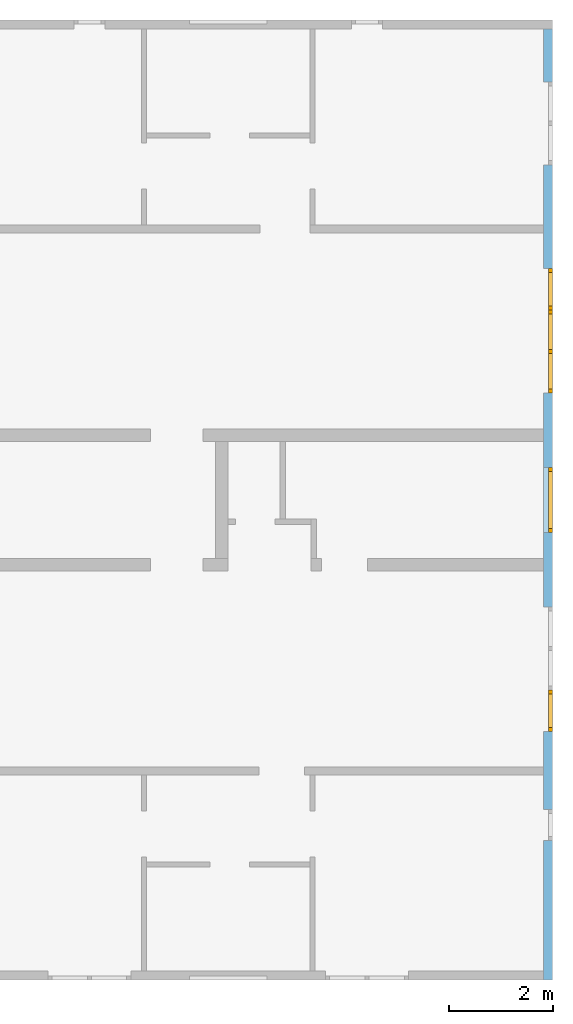
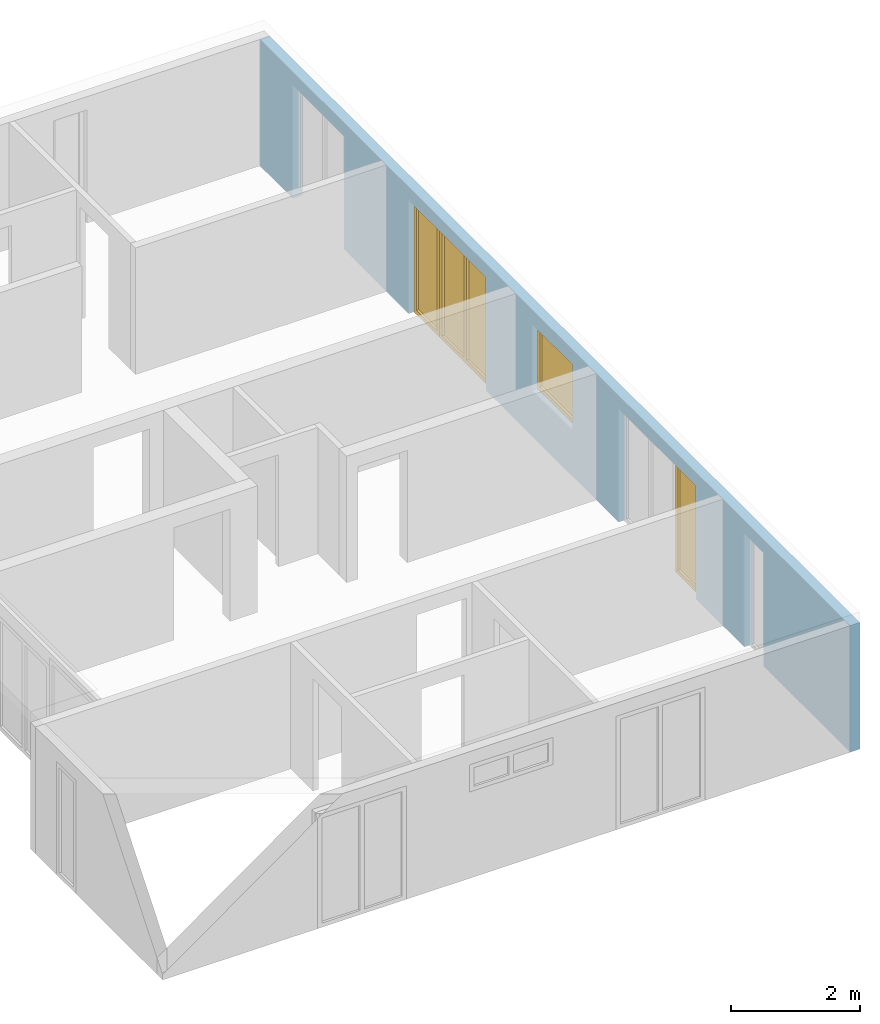
# One storey, part 7 of 8: 4 windows, 7 openings, plus 1 element that does not belong to this part.
"""IFC2X3 building model written with IfcOpenShell, lengths in millimetres."""

from ifc_helpers import new_model, entity, si_unit, converted_unit, frame, frame_2d, origin, origin_with_axes, place, context, project, spatial, rectangle, extrude, faceted_brep, material, layer, layer_set, layer_usage, element, fill, save


model = new_model("IFC2X3")

# Units and contexts
model_context = context("Model", 3, precision=1e-05, world=origin())
plan_context = context("Plan", 3, precision=1e-05, world=origin())
ifc_project = project(units=[si_unit("LENGTHUNIT", "METRE", prefix="MILLI"), converted_unit("PLANEANGLEUNIT", "DEGREE", entity("IfcPlaneAngleMeasure", 0.0174532925199433), si_unit("PLANEANGLEUNIT", "RADIAN"), dimensions=[0, 0, 0, 0, 0, 0, 0]), si_unit("AREAUNIT", "SQUARE_METRE"), si_unit("VOLUMEUNIT", "CUBIC_METRE")], contexts=[model_context, plan_context])

# Building, storey
building_placement = place(None, origin())
building = spatial("IfcBuilding", under=ifc_project, at=building_placement, CompositionType="ELEMENT")
storey_placement = place(building_placement, frame((0.0, 0.0, 2900.0), z_axis=(0.0, 0.0, 1.0), x_axis=(1.0, 0.0, 0.0)))
storey = spatial("IfcBuildingStorey", under=building, at=storey_placement, Name="OG", CompositionType="ELEMENT", Elevation=2900.0)

# Wall, openings, windows
ifc_material_1 = material(Name="B25")
ifc_layer = layer(ifc_material_1, 175.000000044703)
ifc_layer_set = layer_set([ifc_layer])
ifc_layer_usage = layer_usage(ifc_layer_set, "AXIS2", "POSITIVE", 0.0)
wall_placement = place(storey_placement, frame((33688.3517822139, -8691.5625, 0.0), z_axis=(0.0, 0.0, 1.0), x_axis=(0.0, 1.0, 0.0)))
wall = element("IfcWallStandardCase", 1, at=wall_placement, inside=storey, material=ifc_layer_usage, context=model_context, shape_type="SweptSolid", body=[
    extrude(rectangle(XDim=18325.0, YDim=175.000000044703, at=frame_2d((9162.5, 87.5000000223517), x_axis=(1.0, 0.0))), origin_with_axes(), (0.0, 0.0, 1.0), 2400.0),
])
opening_1_placement = place(wall_placement, frame((2690.0, 0.0, 0.0), z_axis=(0.0, 1.0, 0.0), x_axis=(0.0, 0.0, 1.0)))
element("IfcOpeningElement", 2, at=opening_1_placement, cuts=wall, ObjectType="Opening", context=model_context, shape_type="SweptSolid", body=[
    extrude(rectangle(XDim=2150.0, YDim=600.0, at=frame_2d((1075.0, 300.0), x_axis=(1.0, 0.0))), origin_with_axes(), (0.0, 0.0, 1.0), 175.000000044703),
])
opening_2_placement = place(wall_placement, frame((5590.0, 0.0, 0.0), z_axis=(0.0, 1.0, 0.0), x_axis=(0.0, 0.0, 1.0)))
element("IfcOpeningElement", 3, at=opening_2_placement, cuts=wall, ObjectType="Opening", context=model_context, shape_type="SweptSolid", body=[
    extrude(rectangle(XDim=2150.0, YDim=1600.0, at=frame_2d((1075.0, 800.0), x_axis=(1.0, 0.0))), origin_with_axes(), (0.0, 0.0, 1.0), 175.000000044703),
])
opening_3_placement = place(wall_placement, frame((15710.0, 0.0, 0.0), z_axis=(0.0, 1.0, 0.0), x_axis=(0.0, 0.0, 1.0)))
element("IfcOpeningElement", 4, at=opening_3_placement, cuts=wall, ObjectType="Opening", context=model_context, shape_type="SweptSolid", body=[
    extrude(rectangle(XDim=2150.0, YDim=1600.0, at=frame_2d((1075.0, 800.0), x_axis=(1.0, 0.0))), origin_with_axes(), (0.0, 0.0, 1.0), 175.000000044703),
])
opening_4_placement = place(wall_placement, frame((8625.0, 1.86264514923096e-09, 875.0), z_axis=(0.0, 1.0, 0.0), x_axis=(0.0, 0.0, 1.0)))
opening_4 = element("IfcOpeningElement", 5, at=opening_4_placement, cuts=wall, ObjectType="Opening", context=model_context, shape_type="SweptSolid", body=[
    extrude(rectangle(XDim=1250.0, YDim=1250.0, at=frame_2d((625.0, 625.0), x_axis=(1.0, 0.0))), origin_with_axes(), (0.0, 0.0, 1.0), 175.000000044703),
])
opening_5_placement = place(wall_placement, frame((4790.0, 0.0, 0.0), z_axis=(0.0, 1.0, 0.0), x_axis=(0.0, 0.0, 1.0)))
opening_5 = element("IfcOpeningElement", 6, at=opening_5_placement, cuts=wall, ObjectType="Opening", context=model_context, shape_type="SweptSolid", body=[
    extrude(rectangle(XDim=2150.0, YDim=800.0, at=frame_2d((1075.0, 400.0), x_axis=(1.0, 0.0))), origin_with_axes(), (0.0, 0.0, 1.0), 175.000000044703),
])
opening_6_placement = place(wall_placement, frame((12910.0, 0.0, 0.0), z_axis=(0.0, 1.0, 0.0), x_axis=(0.0, 0.0, 1.0)))
opening_6 = element("IfcOpeningElement", 7, at=opening_6_placement, cuts=wall, ObjectType="Opening", context=model_context, shape_type="SweptSolid", body=[
    extrude(rectangle(XDim=2150.0, YDim=800.0, at=frame_2d((1075.0, 400.0), x_axis=(1.0, 0.0))), origin_with_axes(), (0.0, 0.0, 1.0), 175.000000044703),
])
opening_7_placement = place(wall_placement, frame((11310.0, 0.0, 0.0), z_axis=(0.0, 1.0, 0.0), x_axis=(0.0, 0.0, 1.0)))
opening_7 = element("IfcOpeningElement", 8, at=opening_7_placement, cuts=wall, ObjectType="Opening", context=model_context, shape_type="SweptSolid", body=[
    extrude(rectangle(XDim=2150.0, YDim=1600.0, at=frame_2d((1075.0, 800.0), x_axis=(1.0, 0.0))), origin_with_axes(), (0.0, 0.0, 1.0), 175.000000044703),
])
ifc_material_2 = material()
window_1_placement = place(opening_4_placement, frame((0.0, 0.0, 0.0), z_axis=(1.0, 0.0, 0.0), x_axis=(0.0, 1.0, 0.0)))
window_1 = element("IfcWindow", 9, at=window_1_placement, inside=storey, material=ifc_material_2, Name="m", OverallHeight=1250.0, OverallWidth=1250.0, context=model_context, shape_type="Brep", body=[
    faceted_brep([(1170.0, -1.66655578226482e-12, 0.0), (1170.0, -1.66655578226482e-12, 1250.0), (1250.0, -1.68121072618987e-12, 1250.0), (1250.0, -1.68121072618987e-12, 0.0), (1250.0, 79.9999999999983, 0.0), (1250.0, 79.9999999999983, 1250.0), (1170.0, 79.9999999999983, 1250.0), (1170.0, 79.9999999999983, 0.0), (1250.0, -1.68121072618987e-12, 0.0), (1250.0, 79.9999999999983, 0.0), (1170.0, 79.9999999999983, 0.0), (1170.0, -1.66655578226482e-12, 0.0), (1250.0, -1.68121072618987e-12, 1250.0), (1250.0, 79.9999999999983, 1250.0), (1250.0, 79.9999999999983, 0.0), (1250.0, -1.68121072618987e-12, 0.0), (1170.0, -1.66655578226482e-12, 1250.0), (1170.0, 79.9999999999983, 1250.0), (1250.0, 79.9999999999983, 1250.0), (1250.0, -1.68121072618987e-12, 1250.0), (1170.0, -1.66655578226482e-12, 0.0), (1170.0, 79.9999999999983, 0.0), (1170.0, 79.9999999999983, 1250.0), (1170.0, -1.66655578226482e-12, 1250.0)], [[[0, 1, 2, 3]], [[4, 5, 6, 7]], [[8, 9, 10, 11]], [[12, 13, 14, 15]], [[16, 17, 18, 19]], [[20, 21, 22, 23]]], orient=[[False], [False], [False], [False], [False], [False]]),
    faceted_brep([(80.0, -1.46982426230124e-12, 1250.0), (80.0, -1.46982426230124e-12, 0.0), (-1.4321069287046e-14, -1.45516931837619e-12, 0.0), (-1.4321069287046e-14, -1.45516931837619e-12, 1250.0), (3.74206958822511e-16, 79.9999999999986, 1250.0), (3.74206958822511e-16, 79.9999999999986, 0.0), (80.0, 79.9999999999985, 0.0), (80.0, 79.9999999999985, 1250.0), (-1.4321069287046e-14, -1.45516931837619e-12, 1250.0), (3.74206958822511e-16, 79.9999999999986, 1250.0), (80.0, 79.9999999999985, 1250.0), (80.0, -1.46982426230124e-12, 1250.0), (-1.4321069287046e-14, -1.45516931837619e-12, 0.0), (3.74206958822511e-16, 79.9999999999986, 0.0), (3.74206958822511e-16, 79.9999999999986, 1250.0), (-1.4321069287046e-14, -1.45516931837619e-12, 1250.0), (80.0, -1.46982426230124e-12, 0.0), (80.0, 79.9999999999985, 0.0), (3.74206958822511e-16, 79.9999999999986, 0.0), (-1.4321069287046e-14, -1.45516931837619e-12, 0.0), (80.0, -1.46982426230124e-12, 1250.0), (80.0, 79.9999999999985, 1250.0), (80.0, 79.9999999999985, 0.0), (80.0, -1.46982426230124e-12, 0.0)], [[[0, 1, 2, 3]], [[4, 5, 6, 7]], [[8, 9, 10, 11]], [[12, 13, 14, 15]], [[16, 17, 18, 19]], [[20, 21, 22, 23]]], orient=[[False], [False], [False], [False], [False], [False]]),
    faceted_brep([(1170.0, -1.65589764122842e-12, 1170.0), (80.0, -1.45561340758604e-12, 1170.0), (80.0, -1.45561340758604e-12, 1250.0), (1170.0, -1.65589764122842e-12, 1250.0), (1170.0, 79.9999999999984, 1250.0), (80.0, 79.9999999999986, 1250.0), (80.0, 79.9999999999986, 1170.0), (1170.0, 79.9999999999984, 1170.0), (1170.0, -1.65589764122842e-12, 1250.0), (1170.0, 79.9999999999984, 1250.0), (1170.0, 79.9999999999984, 1170.0), (1170.0, -1.65589764122842e-12, 1170.0), (80.0, -1.45561340758604e-12, 1250.0), (80.0, 79.9999999999986, 1250.0), (1170.0, 79.9999999999984, 1250.0), (1170.0, -1.65589764122842e-12, 1250.0), (80.0, -1.45561340758604e-12, 1170.0), (80.0, 79.9999999999986, 1170.0), (80.0, 79.9999999999986, 1250.0), (80.0, -1.45561340758604e-12, 1250.0), (1170.0, -1.65589764122842e-12, 1170.0), (1170.0, 79.9999999999984, 1170.0), (80.0, 79.9999999999986, 1170.0), (80.0, -1.45561340758604e-12, 1170.0)], [[[0, 1, 2, 3]], [[4, 5, 6, 7]], [[8, 9, 10, 11]], [[12, 13, 14, 15]], [[16, 17, 18, 19]], [[20, 21, 22, 23]]], orient=[[False], [False], [False], [False], [False], [False]]),
    faceted_brep([(80.0, -1.45561340758604e-12, 80.0), (1170.0, -1.65589764122842e-12, 80.0), (1170.0, -1.65589764122842e-12, 0.0), (80.0, -1.45561340758604e-12, 0.0), (80.0, 79.9999999999986, 0.0), (1170.0, 79.9999999999984, 0.0), (1170.0, 79.9999999999984, 80.0), (80.0, 79.9999999999986, 80.0), (80.0, -1.45561340758604e-12, 0.0), (80.0, 79.9999999999986, 0.0), (80.0, 79.9999999999986, 80.0), (80.0, -1.45561340758604e-12, 80.0), (1170.0, -1.65589764122842e-12, 0.0), (1170.0, 79.9999999999984, 0.0), (80.0, 79.9999999999986, 0.0), (80.0, -1.45561340758604e-12, 0.0), (1170.0, -1.65589764122842e-12, 80.0), (1170.0, 79.9999999999984, 80.0), (1170.0, 79.9999999999984, 0.0), (1170.0, -1.65589764122842e-12, 0.0), (80.0, -1.45561340758604e-12, 80.0), (80.0, 79.9999999999986, 80.0), (1170.0, 79.9999999999984, 80.0), (1170.0, -1.65589764122842e-12, 80.0)], [[[0, 1, 2, 3]], [[4, 5, 6, 7]], [[8, 9, 10, 11]], [[12, 13, 14, 15]], [[16, 17, 18, 19]], [[20, 21, 22, 23]]], orient=[[False], [False], [False], [False], [False], [False]]),
    faceted_brep([(1170.0, 39.9999999999983, 80.0), (80.0, 39.9999999999985, 80.0), (80.0, 39.9999999999985, 1170.0), (1170.0, 39.9999999999983, 1170.0), (1170.0, 40.9999999999983, 80.0), (1170.0, 40.9999999999983, 1170.0), (80.0, 40.9999999999985, 1170.0), (80.0, 40.9999999999985, 80.0), (1170.0, 39.9999999999983, 80.0), (1170.0, 40.9999999999983, 80.0), (80.0, 40.9999999999985, 80.0), (80.0, 39.9999999999985, 80.0), (80.0, 39.9999999999985, 80.0), (80.0, 40.9999999999985, 80.0), (80.0, 40.9999999999985, 1170.0), (80.0, 39.9999999999985, 1170.0), (80.0, 39.9999999999985, 1170.0), (80.0, 40.9999999999985, 1170.0), (1170.0, 40.9999999999983, 1170.0), (1170.0, 39.9999999999983, 1170.0), (1170.0, 39.9999999999983, 1170.0), (1170.0, 40.9999999999983, 1170.0), (1170.0, 40.9999999999983, 80.0), (1170.0, 39.9999999999983, 80.0)], [[[0, 1, 2, 3]], [[4, 5, 6, 7]], [[8, 9, 10, 11]], [[12, 13, 14, 15]], [[16, 17, 18, 19]], [[20, 21, 22, 23]]], orient=[[False], [False], [False], [False], [False], [False]]),
])
fill(opening_4, window_1)
ifc_material_3 = material()
window_2_placement = place(opening_5_placement, frame((0.0, 0.0, 0.0), z_axis=(1.0, 0.0, 0.0), x_axis=(0.0, 1.0, 0.0)))
window_2 = element("IfcWindow", 10, at=window_2_placement, inside=storey, material=ifc_material_3, Name="m", OverallHeight=2150.0, OverallWidth=800.0, context=model_context, shape_type="Brep", body=[
    faceted_brep([(80.0, 4.19088097558529e-11, 0.0), (0.0, 4.19235757220804e-11, 0.0), (0.0, 4.19235757220804e-11, 2150.0), (80.0, 4.19088097558529e-11, 2150.0), (0.0, 80.0000000000419, 0.0), (80.0, 80.0000000000419, 0.0), (80.0, 80.0000000000419, 2150.0), (0.0, 80.0000000000419, 2150.0), (0.0, 4.19235757220804e-11, 0.0), (80.0, 4.19088097558529e-11, 0.0), (80.0, 80.0000000000419, 0.0), (0.0, 80.0000000000419, 0.0), (0.0, 4.19235757220804e-11, 2150.0), (0.0, 4.19235757220804e-11, 0.0), (0.0, 80.0000000000419, 0.0), (0.0, 80.0000000000419, 2150.0), (80.0, 4.19088097558529e-11, 2150.0), (0.0, 4.19235757220804e-11, 2150.0), (0.0, 80.0000000000419, 2150.0), (80.0, 80.0000000000419, 2150.0), (80.0, 4.19088097558529e-11, 0.0), (80.0, 4.19088097558529e-11, 2150.0), (80.0, 80.0000000000419, 2150.0), (80.0, 80.0000000000419, 0.0)], [[[0, 1, 2, 3]], [[4, 5, 6, 7]], [[8, 9, 10, 11]], [[12, 13, 14, 15]], [[16, 17, 18, 19]], [[20, 21, 22, 23]]], orient=[[False], [False], [False], [False], [False], [False]]),
    faceted_brep([(720.0, 4.17628154281147e-11, 2150.0), (800.0, 4.17481604841896e-11, 2150.0), (800.0, 4.17481604841896e-11, 0.0), (720.0, 4.17628154281147e-11, 0.0), (800.0, 80.0000000000418, 2150.0), (720.0, 80.0000000000418, 2150.0), (720.0, 80.0000000000418, 0.0), (800.0, 80.0000000000418, 0.0), (800.0, 4.17481604841896e-11, 2150.0), (720.0, 4.17628154281147e-11, 2150.0), (720.0, 80.0000000000418, 2150.0), (800.0, 80.0000000000418, 2150.0), (800.0, 4.17481604841896e-11, 0.0), (800.0, 4.17481604841896e-11, 2150.0), (800.0, 80.0000000000418, 2150.0), (800.0, 80.0000000000418, 0.0), (720.0, 4.17628154281147e-11, 0.0), (800.0, 4.17481604841896e-11, 0.0), (800.0, 80.0000000000418, 0.0), (720.0, 80.0000000000418, 0.0), (720.0, 4.17628154281147e-11, 2150.0), (720.0, 4.17628154281147e-11, 0.0), (720.0, 80.0000000000418, 0.0), (720.0, 80.0000000000418, 2150.0)], [[[0, 1, 2, 3]], [[4, 5, 6, 7]], [[8, 9, 10, 11]], [[12, 13, 14, 15]], [[16, 17, 18, 19]], [[20, 21, 22, 23]]], orient=[[False], [False], [False], [False], [False], [False]]),
    faceted_brep([(720.0, 4.17486045733995e-11, 80.0), (720.0, 4.17486045733995e-11, 0.0), (80.0, 4.18661771917073e-11, 0.0), (80.0, 4.18661771917073e-11, 80.0), (720.0, 80.0000000000418, 0.0), (720.0, 80.0000000000418, 80.0), (80.0, 80.0000000000419, 80.0), (80.0, 80.0000000000419, 0.0), (720.0, 4.17486045733995e-11, 0.0), (720.0, 4.17486045733995e-11, 80.0), (720.0, 80.0000000000418, 80.0), (720.0, 80.0000000000418, 0.0), (80.0, 4.18661771917073e-11, 0.0), (720.0, 4.17486045733995e-11, 0.0), (720.0, 80.0000000000418, 0.0), (80.0, 80.0000000000419, 0.0), (80.0, 4.18661771917073e-11, 80.0), (80.0, 4.18661771917073e-11, 0.0), (80.0, 80.0000000000419, 0.0), (80.0, 80.0000000000419, 80.0), (720.0, 4.17486045733995e-11, 80.0), (80.0, 4.18661771917073e-11, 80.0), (80.0, 80.0000000000419, 80.0), (720.0, 80.0000000000418, 80.0)], [[[0, 1, 2, 3]], [[4, 5, 6, 7]], [[8, 9, 10, 11]], [[12, 13, 14, 15]], [[16, 17, 18, 19]], [[20, 21, 22, 23]]], orient=[[False], [False], [False], [False], [False], [False]]),
    faceted_brep([(80.0, 4.18661771917073e-11, 2070.0), (80.0, 4.18661771917073e-11, 2150.0), (720.0, 4.17486045733995e-11, 2150.0), (720.0, 4.17486045733995e-11, 2070.0), (80.0, 80.0000000000419, 2150.0), (80.0, 80.0000000000419, 2070.0), (720.0, 80.0000000000418, 2070.0), (720.0, 80.0000000000418, 2150.0), (80.0, 4.18661771917073e-11, 2150.0), (80.0, 4.18661771917073e-11, 2070.0), (80.0, 80.0000000000419, 2070.0), (80.0, 80.0000000000419, 2150.0), (720.0, 4.17486045733995e-11, 2150.0), (80.0, 4.18661771917073e-11, 2150.0), (80.0, 80.0000000000419, 2150.0), (720.0, 80.0000000000418, 2150.0), (720.0, 4.17486045733995e-11, 2070.0), (720.0, 4.17486045733995e-11, 2150.0), (720.0, 80.0000000000418, 2150.0), (720.0, 80.0000000000418, 2070.0), (80.0, 4.18661771917073e-11, 2070.0), (720.0, 4.17486045733995e-11, 2070.0), (720.0, 80.0000000000418, 2070.0), (80.0, 80.0000000000419, 2070.0)], [[[0, 1, 2, 3]], [[4, 5, 6, 7]], [[8, 9, 10, 11]], [[12, 13, 14, 15]], [[16, 17, 18, 19]], [[20, 21, 22, 23]]], orient=[[False], [False], [False], [False], [False], [False]]),
    faceted_brep([(720.0, 40.0000000000418, 2070.0), (720.0, 40.0000000000418, 80.0), (80.0, 40.0000000000419, 80.0), (80.0, 40.0000000000419, 2070.0), (720.0, 41.0000000000418, 2070.0), (80.0, 41.0000000000419, 2070.0), (80.0, 41.0000000000419, 80.0), (720.0, 41.0000000000418, 80.0), (720.0, 40.0000000000418, 2070.0), (720.0, 41.0000000000418, 2070.0), (720.0, 41.0000000000418, 80.0), (720.0, 40.0000000000418, 80.0), (720.0, 40.0000000000418, 80.0), (720.0, 41.0000000000418, 80.0), (80.0, 41.0000000000419, 80.0), (80.0, 40.0000000000419, 80.0), (80.0, 40.0000000000419, 80.0), (80.0, 41.0000000000419, 80.0), (80.0, 41.0000000000419, 2070.0), (80.0, 40.0000000000419, 2070.0), (80.0, 40.0000000000419, 2070.0), (80.0, 41.0000000000419, 2070.0), (720.0, 41.0000000000418, 2070.0), (720.0, 40.0000000000418, 2070.0)], [[[0, 1, 2, 3]], [[4, 5, 6, 7]], [[8, 9, 10, 11]], [[12, 13, 14, 15]], [[16, 17, 18, 19]], [[20, 21, 22, 23]]], orient=[[False], [False], [False], [False], [False], [False]]),
])
fill(opening_5, window_2)
ifc_material_4 = material()
window_3_placement = place(opening_6_placement, frame((0.0, 0.0, 0.0), z_axis=(1.0, 0.0, 0.0), x_axis=(0.0, 1.0, 0.0)))
window_3 = element("IfcWindow", 11, at=window_3_placement, inside=storey, material=ifc_material_4, Name="m", OverallHeight=2150.0, OverallWidth=800.0, context=model_context, shape_type="Brep", body=[
    faceted_brep([(720.0, 4.16017220672416e-11, 0.0), (720.0, 4.16017220672416e-11, 2150.0), (800.0, 4.1586956101014e-11, 2150.0), (800.0, 4.1586956101014e-11, 0.0), (800.0, 80.0000000000416, 0.0), (800.0, 80.0000000000416, 2150.0), (720.0, 80.0000000000416, 2150.0), (720.0, 80.0000000000416, 0.0), (800.0, 4.1586956101014e-11, 0.0), (800.0, 80.0000000000416, 0.0), (720.0, 80.0000000000416, 0.0), (720.0, 4.16017220672416e-11, 0.0), (800.0, 4.1586956101014e-11, 2150.0), (800.0, 80.0000000000416, 2150.0), (800.0, 80.0000000000416, 0.0), (800.0, 4.1586956101014e-11, 0.0), (720.0, 4.16017220672416e-11, 2150.0), (720.0, 80.0000000000416, 2150.0), (800.0, 80.0000000000416, 2150.0), (800.0, 4.1586956101014e-11, 2150.0), (720.0, 4.16017220672416e-11, 0.0), (720.0, 80.0000000000416, 0.0), (720.0, 80.0000000000416, 2150.0), (720.0, 4.16017220672416e-11, 2150.0)], [[[0, 1, 2, 3]], [[4, 5, 6, 7]], [[8, 9, 10, 11]], [[12, 13, 14, 15]], [[16, 17, 18, 19]], [[20, 21, 22, 23]]], orient=[[False], [False], [False], [False], [False], [False]]),
    faceted_brep([(80.0, 4.17335055402646e-11, 2150.0), (80.0, 4.17335055402646e-11, 0.0), (-1.10214571841424e-16, 4.17481604841896e-11, 0.0), (-1.10214571841424e-16, 4.17481604841896e-11, 2150.0), (1.45850616740271e-14, 80.0000000000418, 2150.0), (1.45850616740271e-14, 80.0000000000418, 0.0), (80.0, 80.0000000000417, 0.0), (80.0, 80.0000000000417, 2150.0), (-1.10214571841424e-16, 4.17481604841896e-11, 2150.0), (1.45850616740271e-14, 80.0000000000418, 2150.0), (80.0, 80.0000000000417, 2150.0), (80.0, 4.17335055402646e-11, 2150.0), (-1.10214571841424e-16, 4.17481604841896e-11, 0.0), (1.45850616740271e-14, 80.0000000000418, 0.0), (1.45850616740271e-14, 80.0000000000418, 2150.0), (-1.10214571841424e-16, 4.17481604841896e-11, 2150.0), (80.0, 4.17335055402646e-11, 0.0), (80.0, 80.0000000000417, 0.0), (1.45850616740271e-14, 80.0000000000418, 0.0), (-1.10214571841424e-16, 4.17481604841896e-11, 0.0), (80.0, 4.17335055402646e-11, 2150.0), (80.0, 80.0000000000417, 2150.0), (80.0, 80.0000000000417, 0.0), (80.0, 4.17335055402646e-11, 0.0)], [[[0, 1, 2, 3]], [[4, 5, 6, 7]], [[8, 9, 10, 11]], [[12, 13, 14, 15]], [[16, 17, 18, 19]], [[20, 21, 22, 23]]], orient=[[False], [False], [False], [False], [False], [False]]),
    faceted_brep([(720.0, 4.1630143776672e-11, 2070.0), (80.0, 4.17477163949798e-11, 2070.0), (80.0, 4.17477163949798e-11, 2150.0), (720.0, 4.1630143776672e-11, 2150.0), (720.0, 80.0000000000416, 2150.0), (80.0, 80.0000000000418, 2150.0), (80.0, 80.0000000000418, 2070.0), (720.0, 80.0000000000416, 2070.0), (720.0, 4.1630143776672e-11, 2150.0), (720.0, 80.0000000000416, 2150.0), (720.0, 80.0000000000416, 2070.0), (720.0, 4.1630143776672e-11, 2070.0), (80.0, 4.17477163949798e-11, 2150.0), (80.0, 80.0000000000418, 2150.0), (720.0, 80.0000000000416, 2150.0), (720.0, 4.1630143776672e-11, 2150.0), (80.0, 4.17477163949798e-11, 2070.0), (80.0, 80.0000000000418, 2070.0), (80.0, 80.0000000000418, 2150.0), (80.0, 4.17477163949798e-11, 2150.0), (720.0, 4.1630143776672e-11, 2070.0), (720.0, 80.0000000000416, 2070.0), (80.0, 80.0000000000418, 2070.0), (80.0, 4.17477163949798e-11, 2070.0)], [[[0, 1, 2, 3]], [[4, 5, 6, 7]], [[8, 9, 10, 11]], [[12, 13, 14, 15]], [[16, 17, 18, 19]], [[20, 21, 22, 23]]], orient=[[False], [False], [False], [False], [False], [False]]),
    faceted_brep([(80.0, 4.17477163949798e-11, 80.0), (720.0, 4.1630143776672e-11, 80.0), (720.0, 4.1630143776672e-11, 0.0), (80.0, 4.17477163949798e-11, 0.0), (80.0, 80.0000000000418, 0.0), (720.0, 80.0000000000416, 0.0), (720.0, 80.0000000000416, 80.0), (80.0, 80.0000000000418, 80.0), (80.0, 4.17477163949798e-11, 0.0), (80.0, 80.0000000000418, 0.0), (80.0, 80.0000000000418, 80.0), (80.0, 4.17477163949798e-11, 80.0), (720.0, 4.1630143776672e-11, 0.0), (720.0, 80.0000000000416, 0.0), (80.0, 80.0000000000418, 0.0), (80.0, 4.17477163949798e-11, 0.0), (720.0, 4.1630143776672e-11, 80.0), (720.0, 80.0000000000416, 80.0), (720.0, 80.0000000000416, 0.0), (720.0, 4.1630143776672e-11, 0.0), (80.0, 4.17477163949798e-11, 80.0), (80.0, 80.0000000000418, 80.0), (720.0, 80.0000000000416, 80.0), (720.0, 4.1630143776672e-11, 80.0)], [[[0, 1, 2, 3]], [[4, 5, 6, 7]], [[8, 9, 10, 11]], [[12, 13, 14, 15]], [[16, 17, 18, 19]], [[20, 21, 22, 23]]], orient=[[False], [False], [False], [False], [False], [False]]),
    faceted_brep([(720.0, 40.0000000000416, 80.0), (80.0, 40.0000000000418, 80.0), (80.0, 40.0000000000418, 2070.0), (720.0, 40.0000000000416, 2070.0), (720.0, 41.0000000000416, 80.0), (720.0, 41.0000000000416, 2070.0), (80.0, 41.0000000000418, 2070.0), (80.0, 41.0000000000418, 80.0), (720.0, 40.0000000000416, 80.0), (720.0, 41.0000000000416, 80.0), (80.0, 41.0000000000418, 80.0), (80.0, 40.0000000000418, 80.0), (80.0, 40.0000000000418, 80.0), (80.0, 41.0000000000418, 80.0), (80.0, 41.0000000000418, 2070.0), (80.0, 40.0000000000418, 2070.0), (80.0, 40.0000000000418, 2070.0), (80.0, 41.0000000000418, 2070.0), (720.0, 41.0000000000416, 2070.0), (720.0, 40.0000000000416, 2070.0), (720.0, 40.0000000000416, 2070.0), (720.0, 41.0000000000416, 2070.0), (720.0, 41.0000000000416, 80.0), (720.0, 40.0000000000416, 80.0)], [[[0, 1, 2, 3]], [[4, 5, 6, 7]], [[8, 9, 10, 11]], [[12, 13, 14, 15]], [[16, 17, 18, 19]], [[20, 21, 22, 23]]], orient=[[False], [False], [False], [False], [False], [False]]),
])
fill(opening_6, window_3)
ifc_material_5 = material()
window_4_placement = place(opening_7_placement, frame((0.0, 0.0, 0.0), z_axis=(1.0, 0.0, 0.0), x_axis=(0.0, 1.0, 0.0)))
window_4 = element("IfcWindow", 12, at=window_4_placement, inside=storey, material=ifc_material_5, Name="m", OverallHeight=2150.0, OverallWidth=1600.0, context=model_context, shape_type="Brep", body=[
    faceted_brep([(80.0000000000005, 4.2041592429598e-11, 0.0), (4.54747350886464e-13, 4.20562473735231e-11, 0.0), (4.54747350886464e-13, 4.20562473735231e-11, 2150.0), (80.0000000000005, 4.2041592429598e-11, 2150.0), (4.54747350886464e-13, 80.0000000000421, 0.0), (80.0000000000005, 80.0000000000421, 0.0), (80.0000000000005, 80.0000000000421, 2150.0), (4.54747350886464e-13, 80.0000000000421, 2150.0), (4.54747350886464e-13, 4.20562473735231e-11, 0.0), (80.0000000000005, 4.2041592429598e-11, 0.0), (80.0000000000005, 80.0000000000421, 0.0), (4.54747350886464e-13, 80.0000000000421, 0.0), (4.54747350886464e-13, 4.20562473735231e-11, 2150.0), (4.54747350886464e-13, 4.20562473735231e-11, 0.0), (4.54747350886464e-13, 80.0000000000421, 0.0), (4.54747350886464e-13, 80.0000000000421, 2150.0), (80.0000000000005, 4.2041592429598e-11, 2150.0), (4.54747350886464e-13, 4.20562473735231e-11, 2150.0), (4.54747350886464e-13, 80.0000000000421, 2150.0), (80.0000000000005, 80.0000000000421, 2150.0), (80.0000000000005, 4.2041592429598e-11, 0.0), (80.0000000000005, 4.2041592429598e-11, 2150.0), (80.0000000000005, 80.0000000000421, 2150.0), (80.0000000000005, 80.0000000000421, 0.0)], [[[0, 1, 2, 3]], [[4, 5, 6, 7]], [[8, 9, 10, 11]], [[12, 13, 14, 15]], [[16, 17, 18, 19]], [[20, 21, 22, 23]]], orient=[[False], [False], [False], [False], [False], [False]]),
    faceted_brep([(1520.0, 4.17628154281147e-11, 2150.0), (1600.0, 4.17481604841896e-11, 2150.0), (1600.0, 4.17481604841896e-11, 0.0), (1520.0, 4.17628154281147e-11, 0.0), (1600.0, 80.0000000000418, 2150.0), (1520.0, 80.0000000000418, 2150.0), (1520.0, 80.0000000000418, 0.0), (1600.0, 80.0000000000418, 0.0), (1600.0, 4.17481604841896e-11, 2150.0), (1520.0, 4.17628154281147e-11, 2150.0), (1520.0, 80.0000000000418, 2150.0), (1600.0, 80.0000000000418, 2150.0), (1600.0, 4.17481604841896e-11, 0.0), (1600.0, 4.17481604841896e-11, 2150.0), (1600.0, 80.0000000000418, 2150.0), (1600.0, 80.0000000000418, 0.0), (1520.0, 4.17628154281147e-11, 0.0), (1600.0, 4.17481604841896e-11, 0.0), (1600.0, 80.0000000000418, 0.0), (1520.0, 80.0000000000418, 0.0), (1520.0, 4.17628154281147e-11, 2150.0), (1520.0, 4.17628154281147e-11, 0.0), (1520.0, 80.0000000000418, 0.0), (1520.0, 80.0000000000418, 2150.0)], [[[0, 1, 2, 3]], [[4, 5, 6, 7]], [[8, 9, 10, 11]], [[12, 13, 14, 15]], [[16, 17, 18, 19]], [[20, 21, 22, 23]]], orient=[[False], [False], [False], [False], [False], [False]]),
    faceted_brep([(1520.0, 4.17486045733995e-11, 80.0), (1520.0, 4.17486045733995e-11, 0.0), (80.0000000000005, 4.20131707201676e-11, 0.0), (80.0000000000005, 4.20131707201676e-11, 80.0), (1520.0, 80.0000000000418, 0.0), (1520.0, 80.0000000000418, 80.0), (80.0000000000005, 80.000000000042, 80.0), (80.0000000000005, 80.000000000042, 0.0), (1520.0, 4.17486045733995e-11, 0.0), (1520.0, 4.17486045733995e-11, 80.0), (1520.0, 80.0000000000418, 80.0), (1520.0, 80.0000000000418, 0.0), (80.0000000000005, 4.20131707201676e-11, 0.0), (1520.0, 4.17486045733995e-11, 0.0), (1520.0, 80.0000000000418, 0.0), (80.0000000000005, 80.000000000042, 0.0), (80.0000000000005, 4.20131707201676e-11, 80.0), (80.0000000000005, 4.20131707201676e-11, 0.0), (80.0000000000005, 80.000000000042, 0.0), (80.0000000000005, 80.000000000042, 80.0), (1520.0, 4.17486045733995e-11, 80.0), (80.0000000000005, 4.20131707201676e-11, 80.0), (80.0000000000005, 80.000000000042, 80.0), (1520.0, 80.0000000000418, 80.0)], [[[0, 1, 2, 3]], [[4, 5, 6, 7]], [[8, 9, 10, 11]], [[12, 13, 14, 15]], [[16, 17, 18, 19]], [[20, 21, 22, 23]]], orient=[[False], [False], [False], [False], [False], [False]]),
    faceted_brep([(80.0000000000005, 4.20131707201676e-11, 2070.0), (80.0000000000005, 4.20131707201676e-11, 2150.0), (1520.0, 4.17486045733995e-11, 2150.0), (1520.0, 4.17486045733995e-11, 2070.0), (80.0000000000005, 80.000000000042, 2150.0), (80.0000000000005, 80.000000000042, 2070.0), (1520.0, 80.0000000000418, 2070.0), (1520.0, 80.0000000000418, 2150.0), (80.0000000000005, 4.20131707201676e-11, 2150.0), (80.0000000000005, 4.20131707201676e-11, 2070.0), (80.0000000000005, 80.000000000042, 2070.0), (80.0000000000005, 80.000000000042, 2150.0), (1520.0, 4.17486045733995e-11, 2150.0), (80.0000000000005, 4.20131707201676e-11, 2150.0), (80.0000000000005, 80.000000000042, 2150.0), (1520.0, 80.0000000000418, 2150.0), (1520.0, 4.17486045733995e-11, 2070.0), (1520.0, 4.17486045733995e-11, 2150.0), (1520.0, 80.0000000000418, 2150.0), (1520.0, 80.0000000000418, 2070.0), (80.0000000000005, 4.20131707201676e-11, 2070.0), (1520.0, 4.17486045733995e-11, 2070.0), (1520.0, 80.0000000000418, 2070.0), (80.0000000000005, 80.000000000042, 2070.0)], [[[0, 1, 2, 3]], [[4, 5, 6, 7]], [[8, 9, 10, 11]], [[12, 13, 14, 15]], [[16, 17, 18, 19]], [[20, 21, 22, 23]]], orient=[[False], [False], [False], [False], [False], [False]]),
    faceted_brep([(840.000000000001, 4.19019263731002e-11, 80.0), (760.000000000001, 4.19166923393277e-11, 80.0), (760.000000000001, 4.19166923393277e-11, 2070.0), (840.000000000001, 4.19019263731002e-11, 2070.0), (760.000000000001, 80.0000000000419, 80.0), (840.000000000001, 80.0000000000419, 80.0), (840.000000000001, 80.0000000000419, 2070.0), (760.000000000001, 80.0000000000419, 2070.0), (760.000000000001, 4.19166923393277e-11, 80.0), (840.000000000001, 4.19019263731002e-11, 80.0), (840.000000000001, 80.0000000000419, 80.0), (760.000000000001, 80.0000000000419, 80.0), (760.000000000001, 4.19166923393277e-11, 2070.0), (760.000000000001, 4.19166923393277e-11, 80.0), (760.000000000001, 80.0000000000419, 80.0), (760.000000000001, 80.0000000000419, 2070.0), (840.000000000001, 4.19019263731002e-11, 2070.0), (760.000000000001, 4.19166923393277e-11, 2070.0), (760.000000000001, 80.0000000000419, 2070.0), (840.000000000001, 80.0000000000419, 2070.0), (840.000000000001, 4.19019263731002e-11, 80.0), (840.000000000001, 4.19019263731002e-11, 2070.0), (840.000000000001, 80.0000000000419, 2070.0), (840.000000000001, 80.0000000000419, 80.0)], [[[0, 1, 2, 3]], [[4, 5, 6, 7]], [[8, 9, 10, 11]], [[12, 13, 14, 15]], [[16, 17, 18, 19]], [[20, 21, 22, 23]]], orient=[[False], [False], [False], [False], [False], [False]]),
    faceted_brep([(1520.0, 40.0000000000418, 2070.0), (1520.0, 40.0000000000418, 80.0), (840.000000000001, 40.0000000000419, 80.0), (840.000000000001, 40.0000000000419, 2070.0), (1520.0, 41.0000000000418, 2070.0), (840.000000000001, 41.0000000000419, 2070.0), (840.000000000001, 41.0000000000419, 80.0), (1520.0, 41.0000000000418, 80.0), (1520.0, 40.0000000000418, 2070.0), (1520.0, 41.0000000000418, 2070.0), (1520.0, 41.0000000000418, 80.0), (1520.0, 40.0000000000418, 80.0), (1520.0, 40.0000000000418, 80.0), (1520.0, 41.0000000000418, 80.0), (840.000000000001, 41.0000000000419, 80.0), (840.000000000001, 40.0000000000419, 80.0), (840.000000000001, 40.0000000000419, 80.0), (840.000000000001, 41.0000000000419, 80.0), (840.000000000001, 41.0000000000419, 2070.0), (840.000000000001, 40.0000000000419, 2070.0), (840.000000000001, 40.0000000000419, 2070.0), (840.000000000001, 41.0000000000419, 2070.0), (1520.0, 41.0000000000418, 2070.0), (1520.0, 40.0000000000418, 2070.0)], [[[0, 1, 2, 3]], [[4, 5, 6, 7]], [[8, 9, 10, 11]], [[12, 13, 14, 15]], [[16, 17, 18, 19]], [[20, 21, 22, 23]]], orient=[[False], [False], [False], [False], [False], [False]]),
    faceted_brep([(760.000000000001, 40.0000000000419, 2070.0), (760.000000000001, 40.0000000000419, 80.0), (80.0000000000005, 40.000000000042, 80.0), (80.0000000000005, 40.000000000042, 2070.0), (760.000000000001, 41.0000000000419, 2070.0), (80.0000000000005, 41.000000000042, 2070.0), (80.0000000000005, 41.000000000042, 80.0), (760.000000000001, 41.0000000000419, 80.0), (760.000000000001, 40.0000000000419, 2070.0), (760.000000000001, 41.0000000000419, 2070.0), (760.000000000001, 41.0000000000419, 80.0), (760.000000000001, 40.0000000000419, 80.0), (760.000000000001, 40.0000000000419, 80.0), (760.000000000001, 41.0000000000419, 80.0), (80.0000000000005, 41.000000000042, 80.0), (80.0000000000005, 40.000000000042, 80.0), (80.0000000000005, 40.000000000042, 80.0), (80.0000000000005, 41.000000000042, 80.0), (80.0000000000005, 41.000000000042, 2070.0), (80.0000000000005, 40.000000000042, 2070.0), (80.0000000000005, 40.000000000042, 2070.0), (80.0000000000005, 41.000000000042, 2070.0), (760.000000000001, 41.0000000000419, 2070.0), (760.000000000001, 40.0000000000419, 2070.0)], [[[0, 1, 2, 3]], [[4, 5, 6, 7]], [[8, 9, 10, 11]], [[12, 13, 14, 15]], [[16, 17, 18, 19]], [[20, 21, 22, 23]]], orient=[[False], [False], [False], [False], [False], [False]]),
])
fill(opening_7, window_4)

save(model, "model.ifc")
